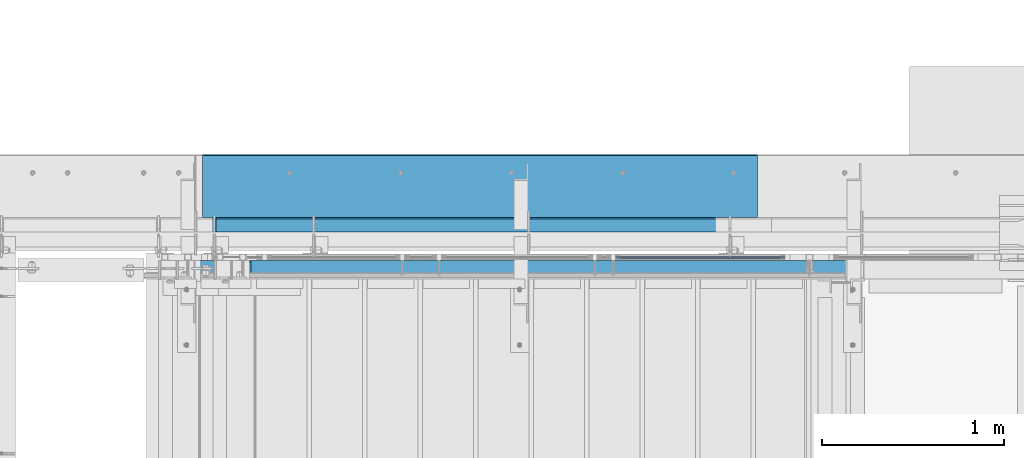
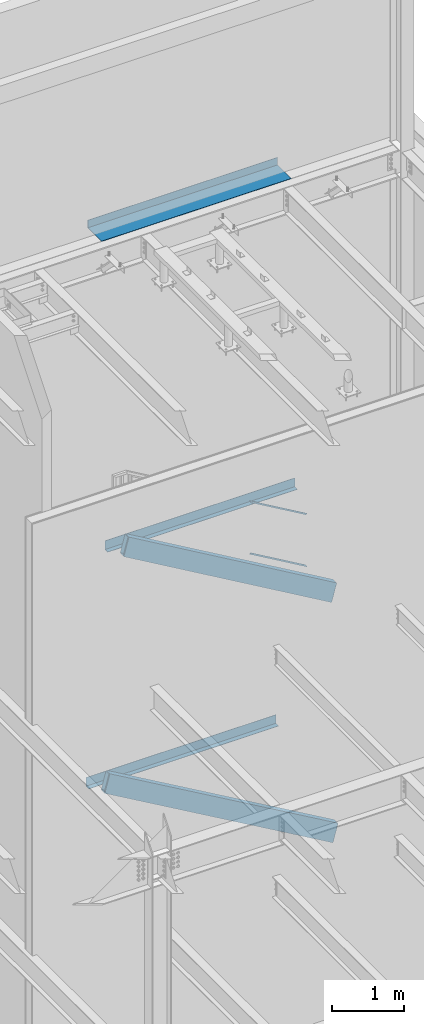
# One storey, part 798 of 1179: 5 beams, 2 members, 6 elements without a shape of their own.
"""IFC2X3 building model written with IfcOpenShell, lengths in millimetres."""

from ifc_helpers import new_model, si_unit, frame, origin_with_axes, place, context, subcontext, project, spatial, faceted_brep, material, type_object, element, aggregate, save


model = new_model("IFC2X3")

# Units and contexts
model_context = context("Model", 3, precision=1e-05, world=origin_with_axes())
body_context = subcontext(model_context, "Body", "Model", "MODEL_VIEW")
ifc_project = project(units=[si_unit("LENGTHUNIT", "METRE", prefix="MILLI"), si_unit("AREAUNIT", "SQUARE_METRE"), si_unit("VOLUMEUNIT", "CUBIC_METRE"), si_unit("MASSUNIT", "GRAM", prefix="KILO"), si_unit("TIMEUNIT", "SECOND"), si_unit("PLANEANGLEUNIT", "RADIAN"), si_unit("SOLIDANGLEUNIT", "STERADIAN"), si_unit("THERMODYNAMICTEMPERATUREUNIT", "DEGREE_CELSIUS"), si_unit("LUMINOUSINTENSITYUNIT", "LUMEN")], contexts=[model_context])

# Site, building, storey
site_placement = place(None, origin_with_axes())
site = spatial("IfcSite", under=ifc_project, at=site_placement, CompositionType="ELEMENT")
building_placement = place(site_placement, origin_with_axes())
building = spatial("IfcBuilding", under=site, at=building_placement, Name="Undefined", CompositionType="ELEMENT")
storey_placement = place(building_placement, origin_with_axes())
storey = spatial("IfcBuildingStorey", under=building, at=storey_placement, Name="Undefined", CompositionType="ELEMENT", Elevation=0.0)

# Assembly, beams
assembly_1_placement = place(storey_placement, origin_with_axes())
assembly_1 = element("IfcElementAssembly", 1, at=assembly_1_placement, inside=storey, Name="GUARDRAIL", AssemblyPlace="NOTDEFINED", PredefinedType="RIGID_FRAME")
ifc_material_1 = material(Name="STEEL/BUY-OUT")
beam_type_1 = type_object("IfcBeamType", PredefinedType="NOTDEFINED")
beam_1_placement = place(assembly_1_placement, frame((22208.4528574912, 41062.2751647691, 6908.98405933235), z_axis=(0.863778851027978, 0.0, -0.503871111016285), x_axis=(-0.503871111016286, 0.0, -0.863778851027978)))
beam_1 = element("IfcBeam", 2, at=beam_1_placement, type_object=beam_type_1, material=ifc_material_1, Name="U-EDGE", context=body_context, shape_type="Brep", body=[
    faceted_brep([(3.02679836750031e-09, 1.58750000000146, -465.424288071716), (3.02316038869321e-09, -1.58750000000146, -465.424288071717), (-3.58704710379243e-09, -1.58750000000146, 550.296660657488), (-3.58704710379243e-09, 1.58750000000146, 550.296660657488), (22.2250000928143, 1.58750000000146, -478.189679507572), (22.2250000632448, 1.58750000000146, 588.991208057043), (22.2250000826898, 4.76250001285371, -478.189679501758), (22.2250000757122, 4.76249998416461, 588.991208078747), (1.59241608344018e-07, 4.76250000984146, -465.424288161439), (1.58372131409124e-07, 4.76249998836283, 550.296660939461), (1.59241608344018e-07, 7.93750000983709, -465.424288161439), (1.58372131409124e-07, 7.93749998836574, 550.296660939461), (25.4000000827036, 7.93750001290027, -480.013306842378), (25.4000000343149, 7.9375, 594.519), (25.4000000928609, -1.58750000000146, -480.013306848216), (25.4000000343149, -1.58750000000146, 594.519)], [[[0, 1, 2, 3]], [[4, 0, 3, 5]], [[6, 4, 5, 7]], [[8, 6, 7, 9]], [[10, 8, 9, 11]], [[12, 10, 11, 13]], [[14, 12, 13, 15]], [[11, 9, 7, 5, 3, 2, 15, 13]], [[1, 14, 15, 2]], [[0, 4, 6, 8, 10, 12, 14, 1]]]),
])
beam_2_placement = place(assembly_1_placement, frame((22182.8562091337, 41062.2751647691, 7773.84859805585), z_axis=(0.863778851027978, 0.0, -0.503871111016285), x_axis=(0.503871025088838, 0.0, 0.863778901152328)))
beam_2 = element("IfcBeam", 3, at=beam_2_placement, type_object=beam_type_1, material=ifc_material_1, Name="U-EDGE", context=body_context, shape_type="Brep", body=[
    faceted_brep([(-1.33470166474581e-07, -4.76249999994616, -435.790965618296), (-1.33470166474581e-07, -7.93749999994907, -435.790965618296), (-1.34041329147294e-07, -7.93750000006548, 579.929993147438), (-1.34041329147294e-07, -4.76250000006257, 579.929993147438), (22.224999933358, -4.76249999989523, -474.486507128395), (22.2249999328378, -4.76250000012806, 592.695373883196), (22.2249999333071, -1.58750000000146, -474.486507128307), (22.2249999328997, -1.58750000000146, 592.695373883229), (2.25554686039686e-10, -1.58750000000146, -435.790965851076), (0.0, -1.58750000000146, 579.92999369853), (2.25554686039686e-10, 1.58750000000146, -435.790965851076), (0.0, 1.58750000000146, 579.92999369853), (25.39999993331, 1.58750000000146, -480.014441613133), (25.3999999489688, 1.58750000000146, 594.519), (25.399999933361, -7.93749999989086, -480.014441613221), (25.3999999489688, -7.9375, 594.519)], [[[0, 1, 2, 3]], [[4, 0, 3, 5]], [[6, 4, 5, 7]], [[8, 6, 7, 9]], [[10, 8, 9, 11]], [[12, 10, 11, 13]], [[14, 12, 13, 15]], [[11, 9, 7, 5, 3, 2, 15, 13]], [[1, 14, 15, 2]], [[0, 4, 6, 8, 10, 12, 14, 1]]]),
])
aggregate(assembly_1, [beam_1, beam_2])

# Assembly, beam
assembly_2_placement = place(storey_placement, origin_with_axes())
assembly_2 = element("IfcElementAssembly", 4, at=assembly_2_placement, inside=storey, Name="BEAM", AssemblyPlace="NOTDEFINED", PredefinedType="RIGID_FRAME")
ifc_material_2 = material(Name="STEEL/A36")
beam_type_2 = type_object("IfcBeamType", PredefinedType="NOTDEFINED")
beam_3_placement = place(assembly_2_placement, frame((20804.9807500839, 41204.3562623834, 3933.82500614879), z_axis=(-1.0, 0.0, 0.0), x_axis=(0.0, 1.0, 0.0)))
beam_3 = element("IfcBeam", 5, at=beam_3_placement, type_object=beam_type_2, material=ifc_material_2, Name="BENT_PLATE", context=body_context, shape_type="Brep", body=[
    faceted_brep([(0.0, -3.17499999999927, -1524.0), (6.00266503170133e-10, -3.17499999922438, 1524.00000000052), (6.00266503170133e-10, 3.17500000077416, 1524.00000000052), (0.0, 3.17499999999927, -1524.0), (78.5812123745636, 3.17500001945837, 1523.99999999984), (78.5812123767537, 3.17500001945837, -1524.00000000016), (72.2312118814298, -3.1749999821136, -1524.00000000014), (72.2312118792324, -3.1749999821136, 1523.99999999986), (78.5812004854306, -149.224999920136, 1523.9999999997), (78.581200490371, -149.224999917277, -1524.0000000003), (72.2312372589367, -149.224999780281, 1524.00000000016), (72.2312372574052, -149.224999781581, -1523.99999999984)], [[[0, 1, 2, 3]], [[3, 2, 4, 5]], [[1, 0, 6, 7]], [[5, 4, 8, 9]], [[4, 2, 1, 7, 10, 8]], [[7, 6, 11, 10]], [[6, 0, 3, 5, 9, 11]], [[10, 11, 9, 8]]]),
])
aggregate(assembly_2, [beam_3])

assembly_3_placement = place(storey_placement, origin_with_axes())
assembly_3 = element("IfcElementAssembly", 6, at=assembly_3_placement, inside=storey, Name="BEAM", AssemblyPlace="NOTDEFINED", PredefinedType="RIGID_FRAME")
beam_4_placement = place(assembly_3_placement, frame((21110.5745000839, 41204.3562633285, 7845.42500614864), z_axis=(-1.0, 0.0, 0.0), x_axis=(0.0, 1.0, 0.0)))
beam_4 = element("IfcBeam", 7, at=beam_4_placement, type_object=beam_type_2, material=ifc_material_2, Name="BENT_PLATE", context=body_context, shape_type="Brep", body=[
    faceted_brep([(0.0, -3.17499999999927, -1524.0), (6.00266503170133e-10, -3.17499999922438, 1524.00000000052), (6.00266503170133e-10, 3.17500000077416, 1524.00000000052), (0.0, 3.17499999999927, -1524.0), (78.5812123745636, 3.17500001945837, 1523.99999999984), (78.5812123767537, 3.17500001945837, -1524.00000000016), (72.2312118814298, -3.1749999821136, -1524.00000000014), (72.2312118792324, -3.1749999821136, 1523.99999999986), (78.5812004854306, -149.224999920136, 1523.9999999997), (78.581200490371, -149.224999917277, -1524.0000000003), (72.2312372589367, -149.224999780281, 1524.00000000016), (72.2312372574052, -149.224999781581, -1523.99999999984)], [[[0, 1, 2, 3]], [[3, 2, 4, 5]], [[1, 0, 6, 7]], [[5, 4, 8, 9]], [[4, 2, 1, 7, 10, 8]], [[7, 6, 11, 10]], [[6, 0, 3, 5, 9, 11]], [[10, 11, 9, 8]]]),
])
aggregate(assembly_3, [beam_4])

assembly_4_placement = place(storey_placement, origin_with_axes())
assembly_4 = element("IfcElementAssembly", 8, at=assembly_4_placement, inside=storey, Name="BEAM", AssemblyPlace="NOTDEFINED", PredefinedType="RIGID_FRAME")
beam_type_3 = type_object("IfcBeamType", PredefinedType="NOTDEFINED")
beam_5_placement = place(assembly_4_placement, frame((21034.375, 41244.838, 13122.275), z_axis=(-1.0, 0.0, 0.0), x_axis=(0.0, 1.0, 0.0)))
beam_5 = element("IfcBeam", 9, at=beam_5_placement, type_object=beam_type_3, material=ifc_material_2, Name="BENT_PLATE", context=body_context, shape_type="Brep", body=[
    faceted_brep([(0.0, -3.17499999999927, -1524.0), (6.00266503170133e-10, -3.17499999922438, 1524.00000000052), (6.00266503170133e-10, 3.17500000077416, 1524.00000000052), (0.0, 3.17499999999927, -1524.0), (385.762000000002, 3.17499999999927, 1524.0), (385.762000000002, 3.17499999999927, -1524.0), (379.411999999997, -3.17499999999927, -1524.0), (379.411999999997, -3.17499999999927, 1524.0), (385.762000000002, -130.175000000001, 1524.0), (385.762000000002, -130.175000000001, -1524.0), (379.411999999997, -130.175000000001, 1524.0), (379.411999999997, -130.175000000001, -1524.0)], [[[0, 1, 2, 3]], [[3, 2, 4, 5]], [[1, 0, 6, 7]], [[5, 4, 8, 9]], [[4, 2, 1, 7, 10, 8]], [[7, 6, 11, 10]], [[6, 0, 3, 5, 9, 11]], [[10, 11, 9, 8]]]),
])
aggregate(assembly_4, [beam_5])

# Assembly, member
assembly_5_placement = place(storey_placement, origin_with_axes())
assembly_5 = element("IfcElementAssembly", 10, at=assembly_5_placement, inside=storey, Name="STAIR", AssemblyPlace="NOTDEFINED", PredefinedType="RIGID_FRAME")
ifc_material_3 = material()
member_type = type_object("IfcMemberType", Name="HSS12X4X3/8", PredefinedType="NOTDEFINED")
member_1_placement = place(assembly_5_placement, frame((23044.9840667634, 40995.6000000005, 6110.4100955455), z_axis=(0.503871025088838, 0.0, 0.863778901152328), x_axis=(-0.863778900717086, 0.0, 0.503871025834967)))
member_1 = element("IfcMember", 11, at=member_1_placement, type_object=member_type, material=ifc_material_3, Name="STAIR", ObjectType="HSS12X4X3/8", context=body_context, shape_type="Brep", body=[
    faceted_brep([(3789.27948303458, -50.8000000000029, -152.400000003301), (3801.72150540223, -41.2750000000015, -142.875000003311), (3878.97377268072, -41.2750000000015, 142.874999996493), (3871.68135952609, -50.8000000000029, 152.399999996509), (3801.72150540223, 41.2750000000015, -142.875000003311), (3789.27948303458, 50.8000000000029, -152.400000003297), (3871.68135952609, 50.8000000000029, 152.399999996494), (3878.97377268072, 41.2750000000015, 142.874999996493), (9.86694677204105, -50.8000000000029, 152.400000000649), (-2.57507558227371, -41.2750000000015, 142.874999999935), (-79.8273428607608, -41.2750000000015, -142.874999999865), (-72.5354716336769, -50.8000000000029, -152.400000000493), (-2.57507558227371, 41.2750000000015, 142.874999999935), (9.86694677204468, 50.8000000000029, 152.39999999994), (-72.5354716336769, 50.8000000000029, -152.39999999987), (-79.8273428607608, 41.2750000000015, -142.874999999865)], [[[0, 1, 2, 3]], [[4, 5, 6, 7]], [[8, 9, 10, 11]], [[12, 13, 14, 15]], [[5, 4, 1, 0]], [[9, 12, 7, 2]], [[15, 14, 11, 10]], [[13, 12, 9, 8]], [[13, 8, 3, 6]], [[7, 6, 3, 2]], [[10, 9, 2, 1]], [[15, 10, 1, 4]], [[12, 15, 4, 7]], [[14, 13, 6, 5]], [[11, 14, 5, 0]], [[8, 11, 0, 3]]]),
])
aggregate(assembly_5, [member_1])

assembly_6_placement = place(storey_placement, origin_with_axes())
assembly_6 = element("IfcElementAssembly", 12, at=assembly_6_placement, inside=storey, Name="STAIR", AssemblyPlace="NOTDEFINED", PredefinedType="RIGID_FRAME")
member_2_placement = place(assembly_6_placement, frame((23066.9755983609, 40995.6000000002, 2023.93664694047), z_axis=(0.501065882891522, 0.0, 0.865409140812679), x_axis=(-0.86540914081267, 0.0, 0.501065882891537)))
member_2 = element("IfcMember", 13, at=member_2_placement, type_object=member_type, material=ifc_material_3, Name="STAIR", ObjectType="HSS12X4X3/8", context=body_context, shape_type="Brep", body=[
    faceted_brep([(-72.0094215624777, 50.8000000000029, -152.399999999898), (-79.3135540918956, 41.2750000000001, -142.875), (-2.55850173872022, 41.2750000000001, 142.875), (9.86264972250137, 50.8, 152.400000000118), (-79.3135540918956, -41.2750000000001, -142.875), (-72.0094215624777, -50.8000000000029, -152.399999999798), (9.86264972250137, -50.8, 152.400000000118), (-2.55850173872022, -41.2750000000001, 142.875), (4160.0514962707, -50.8000000000029, -152.400000001811), (4172.47263235742, -41.2750000000015, -142.875000001821), (4249.22768476343, -41.2750000000015, 142.874999998021), (4241.92099979537, -50.8000000000029, 152.399999998021), (4172.47263235742, 41.2750000000015, -142.875000001821), (4160.0514962707, 50.8000000000029, -152.400000001811), (4241.92099979537, 50.8000000000029, 152.399999998021), (4249.22768476343, 41.2750000000015, 142.874999998021)], [[[0, 1, 2, 3]], [[4, 5, 6, 7]], [[8, 9, 10, 11]], [[12, 13, 14, 15]], [[5, 4, 1, 0]], [[13, 8, 5, 0]], [[14, 13, 0, 3]], [[15, 10, 7, 2]], [[7, 6, 3, 2]], [[11, 14, 3, 6]], [[15, 14, 11, 10]], [[2, 1, 12, 15]], [[9, 12, 1, 4]], [[13, 12, 9, 8]], [[4, 7, 10, 9]], [[8, 11, 6, 5]]]),
])
aggregate(assembly_6, [member_2])

save(model, "model.ifc")
